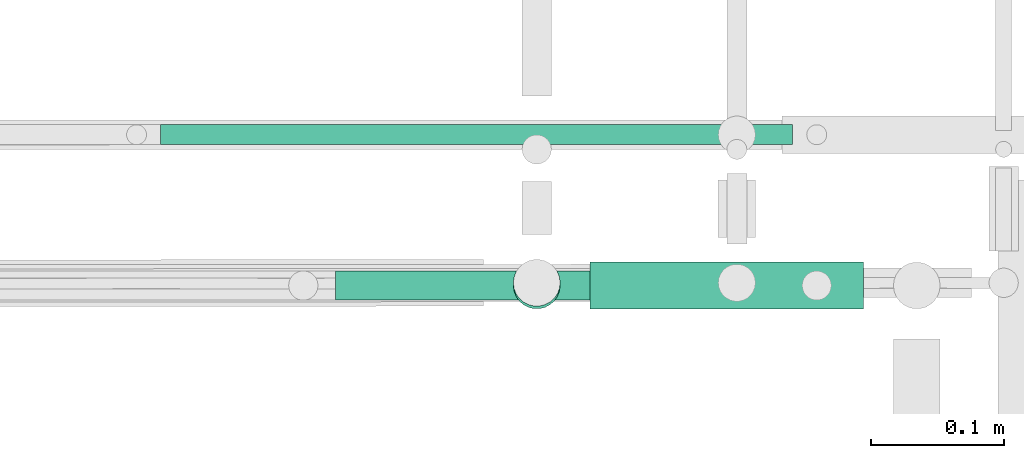
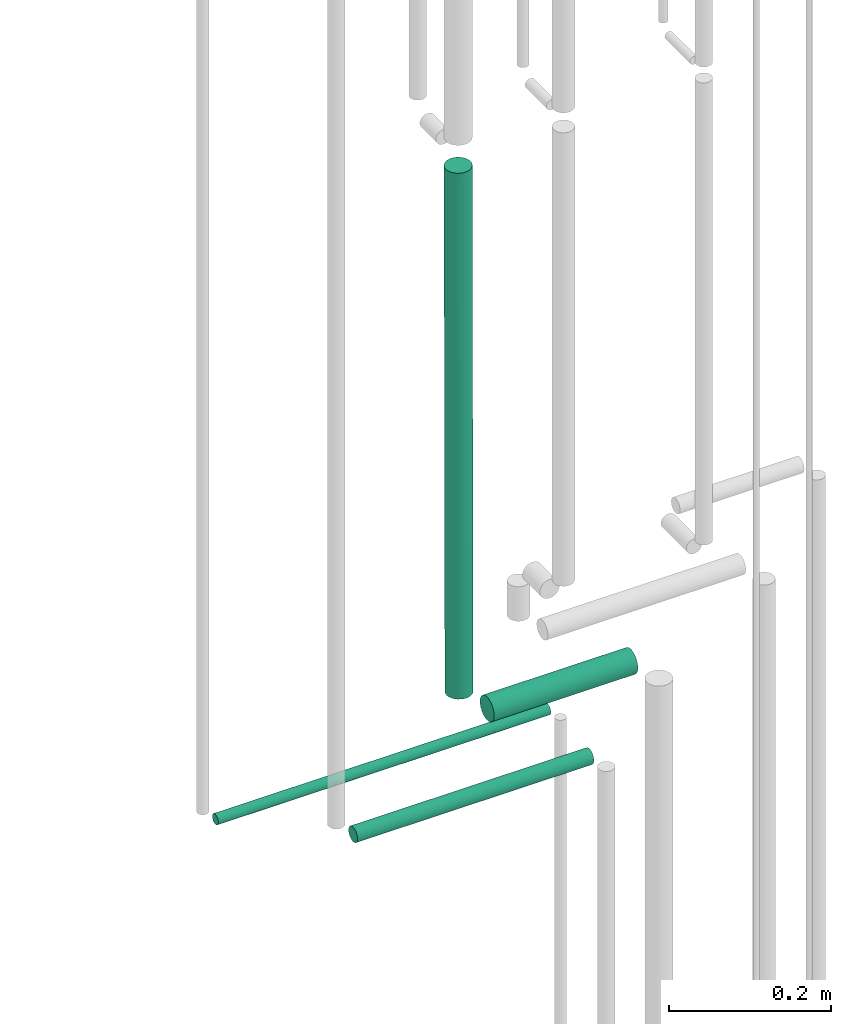
# One storey, part 233 of 331: 4 flow segments.
"""IFC2X3 building model written with IfcOpenShell, lengths in millimetres."""

import ifcopenshell
import ifcopenshell.guid

model = None  # the IFC model being written
_history = None  # IfcOwnerHistory: only IFC2X3 demands one
_inside = {}  # id of a spatial element -> (the spatial element, [elements in it])
_under = {}  # id of a project, library or spatial element -> (it, [spatial elements below it])
_declared = {}  # id of a project -> (the project, [libraries it declares])
_typed = {}  # id of a type object -> (the type object, [elements of that type])
_made_of = {}  # id of a material, layer set ... -> (it, [elements and type objects made of it])


def new_model(schema):
    """Start an empty IFC model of exactly this schema.

    Asked for "IFC4X3", IfcOpenShell would pick the latest addendum, in which some entities
    have other attributes; the version numbers below select the first issue.
    IFC2X3 requires an IfcOwnerHistory on every rooted entity: one is made here for all.
    """
    global model, _history
    if schema == "IFC4X3":
        model = ifcopenshell.file(schema_version=(4, 3, 0, 0))
    else:
        model = ifcopenshell.file(schema=schema)
    _inside.clear()
    _under.clear()
    _declared.clear()
    _typed.clear()
    _made_of.clear()
    _history = None
    if model.schema == "IFC2X3":
        org = make("IfcOrganization", Name="unknown")
        user = make(
            "IfcPersonAndOrganization",
            ThePerson=make("IfcPerson", FamilyName="unknown"),
            TheOrganization=org,
        )
        app = make(
            "IfcApplication",
            ApplicationDeveloper=org,
            Version="unknown",
            ApplicationFullName="unknown",
            ApplicationIdentifier="unknown",
        )
        _history = make(
            "IfcOwnerHistory",
            OwningUser=user,
            OwningApplication=app,
            ChangeAction="ADDED",
            CreationDate=0,
        )
    return model


def make(cls, **values):
    """One entity of the class cls with the attributes given. An attribute that is None is left unset."""
    return model.create_entity(
        cls, **{name: value for name, value in values.items() if value is not None}
    )


def entity(cls, *values):
    """Any entity or typed value of the class cls, its attributes in the order of the schema. None: left unset."""
    e = model.create_entity(cls)
    for i, value in enumerate(values):
        if value is not None:
            e[i] = value
    return e


def rooted(cls, **values):
    """An entity with a GlobalId (a new one), such as an element, a storey or a relation."""
    return make(cls, GlobalId=ifcopenshell.guid.new(), OwnerHistory=_history, **values)


def si_unit(unit_type, name, prefix=None):
    """IfcSIUnit, for example si_unit("LENGTHUNIT", "METRE", prefix="MILLI")."""
    return make("IfcSIUnit", UnitType=unit_type, Prefix=prefix, Name=name)


def converted_unit(unit_type, name, factor, base, dimensions=None, offset=None):
    """IfcConversionBasedUnit, such as the inch: factor (a typed value) times the base unit."""
    return make(
        "IfcConversionBasedUnit"
        if offset is None
        else "IfcConversionBasedUnitWithOffset",
        ConversionOffset=offset,
        Dimensions=None
        if dimensions is None
        else entity("IfcDimensionalExponents", *dimensions),
        UnitType=unit_type,
        Name=name,
        ConversionFactor=make(
            "IfcMeasureWithUnit", ValueComponent=factor, UnitComponent=base
        ),
    )


def derived_unit(unit_type, elements):
    """IfcDerivedUnit: a product of units, each with its exponent."""
    return make(
        "IfcDerivedUnit",
        Elements=[
            make("IfcDerivedUnitElement", Unit=unit, Exponent=power)
            for unit, power in elements
        ],
        UnitType=unit_type,
    )


def assignment(units):
    """IfcUnitAssignment: the units of a project."""
    return None if units is None else make("IfcUnitAssignment", Units=units)


def point(xyz):
    """IfcCartesianPoint."""
    return None if xyz is None else make("IfcCartesianPoint", Coordinates=xyz)


def direction(xyz):
    """IfcDirection."""
    return None if xyz is None else make("IfcDirection", DirectionRatios=xyz)


def frame(location, z_axis=None, x_axis=None):
    """IfcAxis2Placement3D, a coordinate frame: its origin and axes. An axis left out is left unset."""
    return make(
        "IfcAxis2Placement3D",
        Location=point(location),
        Axis=direction(z_axis),
        RefDirection=direction(x_axis),
    )


def frame_2d(location, x_axis=None):
    """IfcAxis2Placement2D, a coordinate frame in the plane: its origin and x axis."""
    return make(
        "IfcAxis2Placement2D", Location=point(location), RefDirection=direction(x_axis)
    )


def origin():
    """The frame at (0, 0, 0) with its axes left unset."""
    return frame((0.0, 0.0, 0.0))


def place(relative_to, where):
    """IfcLocalPlacement: puts the frame where relative to a parent placement (None: the world)."""
    return make(
        "IfcLocalPlacement", PlacementRelTo=relative_to, RelativePlacement=where
    )


def context(
    kind, dimensions, precision=None, world=None, true_north=None, identifier=None
):
    """IfcGeometricRepresentationContext, for example the 3D "Model" context."""
    return make(
        "IfcGeometricRepresentationContext",
        ContextIdentifier=identifier,
        ContextType=kind,
        CoordinateSpaceDimension=dimensions,
        Precision=precision,
        WorldCoordinateSystem=world,
        TrueNorth=true_north,
    )


def subcontext(parent, identifier, kind, view, scale=None):
    """IfcGeometricRepresentationSubContext, for example "Body" below "Model"."""
    return make(
        "IfcGeometricRepresentationSubContext",
        ContextIdentifier=identifier,
        ContextType=kind,
        ParentContext=parent,
        TargetScale=scale,
        TargetView=view,
    )


def project(units=None, contexts=None):
    """IfcProject with its units and contexts."""
    return rooted(
        "IfcProject",
        Name="project",
        RepresentationContexts=contexts,
        UnitsInContext=assignment(units),
    )


def spatial(cls, under=None, at=None, **own):
    """A site, building, storey or space (cls), placed at a placement, below another one or the project."""
    s = rooted(cls, ObjectPlacement=at, **own)
    if under is not None:
        _under.setdefault(under.id(), (under, []))[1].append(s)
    return s


def profile(cls, at=None, kind="AREA", **sizes):
    """A parametric profile (cls). Its sizes go by their IFC names, for example OverallWidth=200.0."""
    return make(cls, ProfileType=kind, Position=at, **sizes)


def circle(**sizes):
    """IfcCircleProfileDef."""
    return profile("IfcCircleProfileDef", **sizes)


def extrude(swept, where, along, depth):
    """IfcExtrudedAreaSolid: the profile swept, set in the frame where, extruded along a direction by depth."""
    return make(
        "IfcExtrudedAreaSolid",
        SweptArea=swept,
        Position=where,
        ExtrudedDirection=direction(along),
        Depth=depth,
    )


def shape(context_of_items, identifier, shape_type, items):
    """IfcShapeRepresentation: the items that make up one representation, for example the "Body"."""
    return make(
        "IfcShapeRepresentation",
        ContextOfItems=context_of_items,
        RepresentationIdentifier=identifier,
        RepresentationType=shape_type,
        Items=items,
    )


def made_of(thing, what):
    """Note that an element or type object is made of a material, layer set ...; save() writes the relation."""
    if what is not None:
        _made_of.setdefault(what.id(), (what, []))[1].append(thing)
    return thing


def type_object(cls, material=None, **own):
    """A type object (cls), such as IfcWallType, which elements share."""
    return made_of(rooted(cls, **own), material)


def element(
    cls,
    number,
    at=None,
    inside=None,
    cuts=None,
    type_object=None,
    material=None,
    context=None,
    identifier="Body",
    shape_type=None,
    held_by="IfcProductDefinitionShape",
    body=None,
    shapes=None,
    **own,
):
    """One element of the class cls, such as IfcWall. Its Tag is "e" and its number.

    at: its placement. inside: the storey or other place that contains it. cuts: it is an
    opening in that element (IfcRelVoidsElement). A single representation is given by context,
    identifier, shape_type and body (its items); several are given by shapes. held_by: the class
    of the entity that holds the representations. save() writes the other relations.
    """
    e = rooted(cls, Tag="e%d" % number, ObjectPlacement=at, **own)
    if body is not None:
        shapes = [shape(context, identifier, shape_type, body)]
    if shapes is not None:
        e.Representation = make(held_by, Representations=shapes)
    if inside is not None:
        _inside.setdefault(inside.id(), (inside, []))[1].append(e)
    if cuts is not None:
        rooted(
            "IfcRelVoidsElement", RelatingBuildingElement=cuts, RelatedOpeningElement=e
        )
    if type_object is not None:
        _typed.setdefault(type_object.id(), (type_object, []))[1].append(e)
    return made_of(e, material)


def aggregate(whole, parts):
    """IfcRelAggregates: a whole, such as a stair, and the parts it consists of."""
    return rooted("IfcRelAggregates", RelatingObject=whole, RelatedObjects=parts)


def save(model, path):
    """Write the relations noted so far, then the file.

    IfcRelAggregates (storeys below a building ...), IfcRelContainedInSpatialStructure (elements
    in a storey), IfcRelDefinesByType, IfcRelAssociatesMaterial and IfcRelDeclares: one each for
    every whole, place, type object, material and project.
    """
    for whole, parts in _under.values():
        aggregate(whole, parts)
    for where, things in _inside.values():
        rooted(
            "IfcRelContainedInSpatialStructure",
            RelatedElements=things,
            RelatingStructure=where,
        )
    for kind, things in _typed.values():
        rooted("IfcRelDefinesByType", RelatedObjects=things, RelatingType=kind)
    for what, things in _made_of.values():
        rooted("IfcRelAssociatesMaterial", RelatedObjects=things, RelatingMaterial=what)
    for by, libraries in _declared.values():
        rooted("IfcRelDeclares", RelatingContext=by, RelatedDefinitions=libraries)
    model.write(path)


model = new_model("IFC2X3")

# Units and contexts
model_context = context("Model", 3, precision=0.01, world=origin(), true_north=direction((6.12303176911189e-17, 1.0)))
body_context = subcontext(model_context, "Body", "Model", "MODEL_VIEW")
ifc_project = project(units=[si_unit("LENGTHUNIT", "METRE", prefix="MILLI"), si_unit("AREAUNIT", "SQUARE_METRE"), si_unit("VOLUMEUNIT", "CUBIC_METRE"), converted_unit("PLANEANGLEUNIT", "DEGREE", entity("IfcRatioMeasure", 0.0174532925199433), si_unit("PLANEANGLEUNIT", "RADIAN"), dimensions=[0, 0, 0, 0, 0, 0, 0]), si_unit("MASSUNIT", "GRAM", prefix="KILO"), derived_unit("MASSDENSITYUNIT", [(si_unit("MASSUNIT", "GRAM", prefix="KILO"), 1), (si_unit("LENGTHUNIT", "METRE"), -3)]), derived_unit("MOMENTOFINERTIAUNIT", [(si_unit("LENGTHUNIT", "METRE"), 4)]), si_unit("TIMEUNIT", "SECOND"), si_unit("FREQUENCYUNIT", "HERTZ"), si_unit("THERMODYNAMICTEMPERATUREUNIT", "DEGREE_CELSIUS"), derived_unit("THERMALTRANSMITTANCEUNIT", [(si_unit("MASSUNIT", "GRAM", prefix="KILO"), 1), (si_unit("THERMODYNAMICTEMPERATUREUNIT", "KELVIN"), -1), (si_unit("TIMEUNIT", "SECOND"), -3)]), derived_unit("VOLUMETRICFLOWRATEUNIT", [(si_unit("LENGTHUNIT", "METRE"), 3), (si_unit("TIMEUNIT", "SECOND"), -1)]), derived_unit("MASSFLOWRATEUNIT", [(si_unit("MASSUNIT", "GRAM", prefix="KILO"), 1), (si_unit("TIMEUNIT", "SECOND"), -1)]), derived_unit("ROTATIONALFREQUENCYUNIT", [(si_unit("TIMEUNIT", "SECOND"), -1)]), si_unit("ELECTRICCURRENTUNIT", "AMPERE"), si_unit("ELECTRICVOLTAGEUNIT", "VOLT"), si_unit("POWERUNIT", "WATT"), si_unit("FORCEUNIT", "NEWTON", prefix="KILO"), si_unit("ILLUMINANCEUNIT", "LUX"), si_unit("LUMINOUSFLUXUNIT", "LUMEN"), si_unit("LUMINOUSINTENSITYUNIT", "CANDELA"), derived_unit("USERDEFINED", [(si_unit("MASSUNIT", "GRAM", prefix="KILO"), -1), (si_unit("LENGTHUNIT", "METRE"), -2), (si_unit("TIMEUNIT", "SECOND"), 3), (si_unit("LUMINOUSFLUXUNIT", "LUMEN"), 1)]), derived_unit("LINEARVELOCITYUNIT", [(si_unit("LENGTHUNIT", "METRE"), 1), (si_unit("TIMEUNIT", "SECOND"), -1)]), si_unit("PRESSUREUNIT", "PASCAL"), derived_unit("USERDEFINED", [(si_unit("LENGTHUNIT", "METRE"), -2), (si_unit("MASSUNIT", "GRAM", prefix="KILO"), 1), (si_unit("TIMEUNIT", "SECOND"), -2)]), derived_unit("LINEARFORCEUNIT", [(si_unit("MASSUNIT", "GRAM", prefix="KILO"), 1), (si_unit("LENGTHUNIT", "METRE"), 1), (si_unit("TIMEUNIT", "SECOND"), -2), (si_unit("LENGTHUNIT", "METRE"), -1)]), derived_unit("PLANARFORCEUNIT", [(si_unit("MASSUNIT", "GRAM", prefix="KILO"), 1), (si_unit("LENGTHUNIT", "METRE"), 1), (si_unit("TIMEUNIT", "SECOND"), -2), (si_unit("LENGTHUNIT", "METRE"), -2)])], contexts=[model_context])

# Site, building, storey
site_placement = place(None, frame((0.0, -0.00077364408347762, 0.0)))
site = spatial("IfcSite", under=ifc_project, at=site_placement, CompositionType="ELEMENT")
building_placement = place(site_placement, origin())
building = spatial("IfcBuilding", under=site, at=building_placement, CompositionType="ELEMENT")
storey_placement = place(building_placement, origin())
storey = spatial("IfcBuildingStorey", under=building, at=storey_placement, CompositionType="ELEMENT", Elevation=0.0)

# Flow segments
pipe_segment_type = type_object("IfcPipeSegmentType", PredefinedType="NOTDEFINED")
flow_segment_1_placement = place(building_placement, frame((66341.0166110417, 8128.84622900159, 4287.7500226646)))
element("IfcFlowSegment", 1, at=flow_segment_1_placement, inside=storey, type_object=pipe_segment_type, context=body_context, shape_type="SweptSolid", body=[
    extrude(circle(Radius=17.5, at=frame_2d((-8.66293703438714e-12, 1.42319158471081e-15), x_axis=(1.0, 0.0))), frame((19.0952722359206, 19.095211779112, 0.0459998314822144), z_axis=(0.0, 0.00262856179895851, 0.999996545325467), x_axis=(1.0, 0.0, 0.0)), (0.0, 0.0, 1.0), 791.206710866435),
])
flow_segment_2_placement = place(building_placement, frame((66078.1118832776, 8251.90500496346, 4115.90475819708)))
element("IfcFlowSegment", 2, at=flow_segment_2_placement, inside=storey, type_object=pipe_segment_type, context=body_context, shape_type="SweptSolid", body=[
    extrude(circle(Radius=7.5, at=frame_2d((1.03062827300139e-41, 1.08286712929839e-12), x_axis=(1.0, 0.0))), frame((0.0, 9.09527223591636, 9.09527223591636), z_axis=(1.0, 0.0, 0.0), x_axis=(0.0, 1.0, 0.0)), (0.0, 0.0, 1.0), 473.885441203071),
])
flow_segment_3_placement = place(building_placement, frame((66209.1118832776, 8135.3349946452, 4112.40475819709)))
element("IfcFlowSegment", 3, at=flow_segment_3_placement, inside=storey, type_object=pipe_segment_type, context=body_context, shape_type="SweptSolid", body=[
    extrude(circle(Radius=11.0, at=frame_2d((-4.33146851719357e-12, 5.41433564649196e-13), x_axis=(1.0, 0.0))), frame((0.0, 12.5952722359199, 12.5952722359161), z_axis=(1.0, 0.0, 0.0), x_axis=(0.0, 1.0, 0.0)), (0.0, 0.0, 1.0), 336.885443382481),
])
flow_segment_4_placement = place(building_placement, frame((66400.1118832776, 8128.84581738411, 4228.70075026172)))
element("IfcFlowSegment", 4, at=flow_segment_4_placement, inside=storey, type_object=pipe_segment_type, context=body_context, shape_type="SweptSolid", body=[
    extrude(circle(Radius=17.5, at=frame_2d((2.16573425859679e-12, -5.41433564649196e-13), x_axis=(1.0, 0.0))), frame((0.0, 19.0952722359184, 19.0952722359163), z_axis=(1.0, 0.0, 0.0), x_axis=(0.0, 1.0, 0.0)), (0.0, 0.0, 1.0), 204.885443382528),
])

save(model, "model.ifc")
